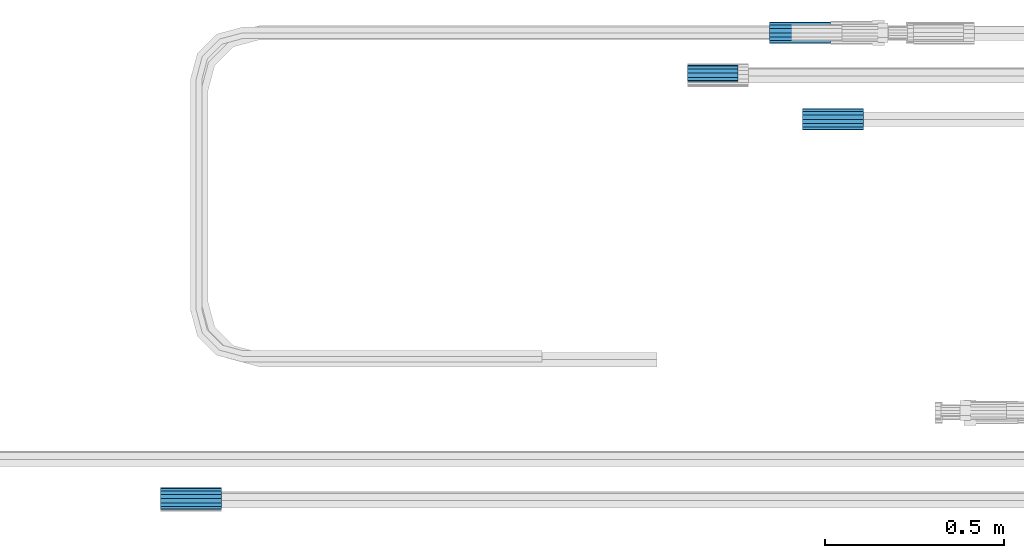
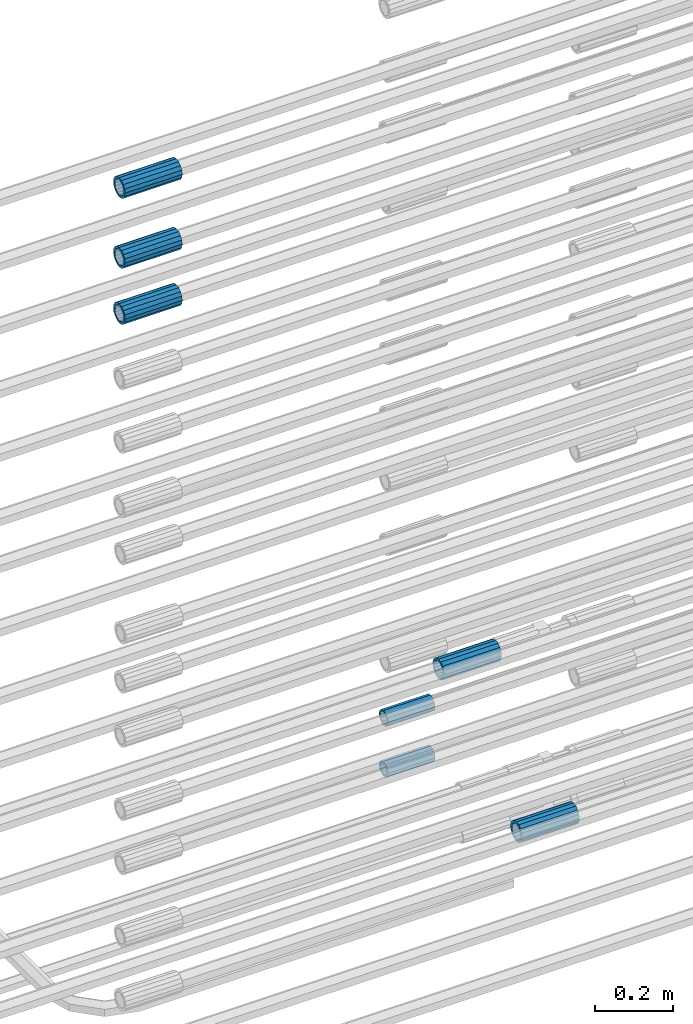
# One storey, part 6 of 119: 7 beams.
"""IFC2X3 building model written with IfcOpenShell, lengths in millimetres."""

from ifc_helpers import new_model, si_unit, frame, origin_with_axes, place, context, subcontext, project, spatial, faceted_brep, material, type_object, element, save


model = new_model("IFC2X3")

# Units and contexts
model_context = context("Model", 3, precision=1e-05, world=origin_with_axes())
body_context = subcontext(model_context, "Body", "Model", "MODEL_VIEW")
ifc_project = project(units=[si_unit("LENGTHUNIT", "METRE", prefix="MILLI"), si_unit("AREAUNIT", "SQUARE_METRE"), si_unit("VOLUMEUNIT", "CUBIC_METRE"), si_unit("MASSUNIT", "GRAM", prefix="KILO"), si_unit("TIMEUNIT", "SECOND"), si_unit("PLANEANGLEUNIT", "RADIAN"), si_unit("SOLIDANGLEUNIT", "STERADIAN"), si_unit("THERMODYNAMICTEMPERATUREUNIT", "DEGREE_CELSIUS"), si_unit("LUMINOUSINTENSITYUNIT", "LUMEN")], contexts=[model_context])

# Site, building, storey
site_placement = place(None, origin_with_axes())
site = spatial("IfcSite", under=ifc_project, at=site_placement, CompositionType="ELEMENT")
building_placement = place(site_placement, origin_with_axes())
building = spatial("IfcBuilding", under=site, at=building_placement, Name="Undefined", CompositionType="ELEMENT")
storey_placement = place(building_placement, origin_with_axes())
storey = spatial("IfcBuildingStorey", under=building, at=storey_placement, Name="Undefined", CompositionType="ELEMENT", Elevation=0.0)

# Beams
ifc_material = material(Name="STEEL/S275")
beam_type_1 = type_object("IfcBeamType", PredefinedType="NOTDEFINED")
beam_1_placement = place(storey_placement, frame((2031709.99007889, 6206160.98994599, 19018.4893064903), z_axis=(0.0, 0.0, 1.0), x_axis=(-0.99999999999998, 1.98000110685822e-07, 0.0)))
element("IfcBeam", 1, at=beam_1_placement, inside=storey, type_object=beam_type_1, material=ifc_material, Name="AG40N", context=body_context, shape_type="Brep", body=[
    faceted_brep([(1.62981450557709e-09, -23.4999999990687, 0.0), (7.45058059692383e-09, -21.7111690142192, 8.99306066057534), (170.000002125278, -21.711168999318, 8.99306066022245), (170.000002127141, -23.4999999844003, -3.66071617463604e-10), (4.65661287307739e-09, -16.6170093587134, 16.6170093578889), (170.000002122484, -16.6170093440451, 16.6170093575288), (1.86264514923096e-09, -8.99306066217832, 21.7111690140277), (170.000002118759, -8.99306064750999, 21.7111690136603), (2.3283064365387e-10, 9.31322574615479e-10, 23.5), (170.000002114102, 1.28056854009628e-08, 23.4999999996485), (-6.51925802230835e-09, 8.99306065868586, 21.7111690140241), (170.00000211224, 8.99306067335419, 21.7111690136639), (-7.45058059692383e-09, 16.6170093561523, 16.6170093578853), (170.000002109446, 16.6170093708206, 16.6170093575324), (-9.31322574615479e-09, 21.711169013055, 8.99306066057534), (170.000002108514, 21.7111690277234, 8.99306066022245), (-1.16415321826935e-09, 23.5000000009313, 0.0), (170.000002108514, 23.5000000144355, -3.66071617463604e-10), (-8.38190317153931e-09, 21.7111690151505, -8.99306066059444), (170.000002110377, 21.7111690300517, -8.9930606609546), (-5.58793544769287e-09, 16.6170093598776, -16.6170093579008), (170.000002113171, 16.6170093745459, -16.6170093582609), (-9.31322574615479e-10, 8.99306066334248, -21.7111690140396), (170.000002115965, 8.99306067801081, -21.7111690143961), (2.3283064365387e-10, 9.31322574615479e-10, -23.5), (170.00000211969, 1.7927959561348e-08, -23.5000000003843), (5.58793544769287e-09, -8.99306065752171, -21.7111690140396), (170.000002123415, -8.99306064285338, -21.7111690143961), (8.38190317153931e-09, -16.6170093549881, -16.6170093579008), (170.000002125278, -16.6170093403198, -16.6170093582646), (9.31322574615479e-09, -21.7111690121237, -8.99306066059444), (170.000002127141, -21.7111689972226, -8.9930606609546), (1.11758708953857e-08, -30.4999999990687, -9.54969436861575e-12), (1.30385160446167e-08, -28.1783257392235, -11.6718446871514), (170.000002129003, -28.1783257243223, -11.6718446875116), (170.000002129935, -30.4999999841675, -3.66071617463604e-10), (1.02445483207703e-08, -21.5667568228673, -21.5667568262129), (170.000002128072, -21.566756808199, -21.5667568265694), (7.45058059692383e-09, -11.6718446831219, -28.1783257416196), (170.000002125278, -11.6718446684536, -28.1783257419834), (3.72529029846191e-09, 3.95812094211578e-09, -30.5000000000277), (170.00000211969, 1.83936208486557e-08, -30.5000000003879), (-9.31322574615479e-10, 11.6718446905725, -28.1783257416232), (170.000002115965, 11.6718447052408, -28.1783257419797), (-6.51925802230835e-09, 21.5667568286881, -21.5667568262093), (170.000002110377, 21.5667568433564, -21.5667568265694), (-9.31322574615479e-09, 28.178325742716, -11.6718446871478), (170.000002108514, 28.1783257573843, -11.6718446875079), (-1.21071934700012e-08, 30.5, -5.91171556152403e-12), (170.000002106652, 30.5000000144355, -3.62433638656512e-10), (-1.21071934700012e-08, 28.1783257401548, 11.6718446871359), (170.00000210572, 28.1783257548232, 11.6718446867794), (-1.02445483207703e-08, 21.5667568240315, 21.5667568261974), (170.000002107583, 21.566756838467, 21.5667568258409), (-7.45058059692383e-09, 11.671844684286, 28.1783257416041), (170.000002110377, 11.6718446989544, 28.178325741244), (-2.79396772384644e-09, -2.56113708019257e-09, 30.5000000000159), (170.000002114102, 1.18743628263474e-08, 30.4999999996558), (1.86264514923096e-09, -11.6718446896411, 28.1783257416114), (170.000002118759, -11.67184467474, 28.178325741244), (7.45058059692383e-09, -21.5667568275239, 21.5667568261974), (170.000002123415, -21.5667568126228, 21.5667568258373), (1.02445483207703e-08, -28.1783257415518, 11.6718446871359), (170.000002127141, -28.1783257271163, 11.6718446867794)], [[[0, 1, 2, 3]], [[1, 4, 5, 2]], [[4, 6, 7, 5]], [[6, 8, 9, 7]], [[8, 10, 11, 9]], [[10, 12, 13, 11]], [[12, 14, 15, 13]], [[14, 16, 17, 15]], [[16, 18, 19, 17]], [[18, 20, 21, 19]], [[20, 22, 23, 21]], [[22, 24, 25, 23]], [[24, 26, 27, 25]], [[26, 28, 29, 27]], [[28, 30, 31, 29]], [[30, 0, 3, 31]], [[32, 33, 34, 35]], [[33, 36, 37, 34]], [[36, 38, 39, 37]], [[38, 40, 41, 39]], [[40, 42, 43, 41]], [[42, 44, 45, 43]], [[44, 46, 47, 45]], [[46, 48, 49, 47]], [[48, 50, 51, 49]], [[50, 52, 53, 51]], [[52, 54, 55, 53]], [[54, 56, 57, 55]], [[56, 58, 59, 57]], [[58, 60, 61, 59]], [[60, 62, 63, 61]], [[62, 32, 35, 63]], [[37, 39, 41, 43, 45, 47, 49, 51, 53, 55, 57, 59, 61, 63, 35, 34], [5, 7, 9, 11, 13, 15, 17, 19, 21, 23, 25, 27, 29, 31, 3, 2]], [[62, 60, 58, 56, 54, 52, 50, 48, 46, 44, 42, 40, 38, 36, 33, 32], [30, 28, 26, 24, 22, 20, 18, 16, 14, 12, 10, 8, 6, 4, 1, 0]]]),
])
beam_2_placement = place(storey_placement, frame((2031448.05849044, 6206402.19622464, 19414.9906870425), z_axis=(0.0, 0.0, 1.0), x_axis=(1.0, 0.0, 0.0)))
element("IfcBeam", 2, at=beam_2_placement, inside=storey, type_object=beam_type_1, material=ifc_material, Name="AG40N", context=body_context, shape_type="Brep", body=[
    faceted_brep([(1.62981450557709e-09, -23.4999999990687, 0.0), (7.45058059692383e-09, -21.7111690142192, 8.99306066057534), (170.000002125278, -21.711168999318, 8.99306066022245), (170.000002127141, -23.4999999844003, -3.66071617463604e-10), (4.65661287307739e-09, -16.6170093587134, 16.6170093578889), (170.000002122484, -16.6170093440451, 16.6170093575288), (1.86264514923096e-09, -8.99306066217832, 21.7111690140277), (170.000002118759, -8.99306064750999, 21.7111690136603), (2.3283064365387e-10, 9.31322574615479e-10, 23.5), (170.000002114102, 1.28056854009628e-08, 23.4999999996485), (-6.51925802230835e-09, 8.99306065868586, 21.7111690140241), (170.00000211224, 8.99306067335419, 21.7111690136639), (-7.45058059692383e-09, 16.6170093561523, 16.6170093578853), (170.000002109446, 16.6170093708206, 16.6170093575324), (-9.31322574615479e-09, 21.711169013055, 8.99306066057534), (170.000002108514, 21.7111690277234, 8.99306066022245), (-1.16415321826935e-09, 23.5000000009313, 0.0), (170.000002108514, 23.5000000144355, -3.66071617463604e-10), (-8.38190317153931e-09, 21.7111690151505, -8.99306066059444), (170.000002110377, 21.7111690300517, -8.9930606609546), (-5.58793544769287e-09, 16.6170093598776, -16.6170093579008), (170.000002113171, 16.6170093745459, -16.6170093582609), (-9.31322574615479e-10, 8.99306066334248, -21.7111690140396), (170.000002115965, 8.99306067801081, -21.7111690143961), (2.3283064365387e-10, 9.31322574615479e-10, -23.5), (170.00000211969, 1.7927959561348e-08, -23.5000000003843), (5.58793544769287e-09, -8.99306065752171, -21.7111690140396), (170.000002123415, -8.99306064285338, -21.7111690143961), (8.38190317153931e-09, -16.6170093549881, -16.6170093579008), (170.000002125278, -16.6170093403198, -16.6170093582646), (9.31322574615479e-09, -21.7111690121237, -8.99306066059444), (170.000002127141, -21.7111689972226, -8.9930606609546), (1.11758708953857e-08, -30.4999999990687, -9.54969436861575e-12), (1.30385160446167e-08, -28.1783257392235, -11.6718446871514), (170.000002129003, -28.1783257243223, -11.6718446875116), (170.000002129935, -30.4999999841675, -3.66071617463604e-10), (1.02445483207703e-08, -21.5667568228673, -21.5667568262129), (170.000002128072, -21.566756808199, -21.5667568265694), (7.45058059692383e-09, -11.6718446831219, -28.1783257416196), (170.000002125278, -11.6718446684536, -28.1783257419834), (3.72529029846191e-09, 3.95812094211578e-09, -30.5000000000277), (170.00000211969, 1.83936208486557e-08, -30.5000000003879), (-9.31322574615479e-10, 11.6718446905725, -28.1783257416232), (170.000002115965, 11.6718447052408, -28.1783257419797), (-6.51925802230835e-09, 21.5667568286881, -21.5667568262093), (170.000002110377, 21.5667568433564, -21.5667568265694), (-9.31322574615479e-09, 28.178325742716, -11.6718446871478), (170.000002108514, 28.1783257573843, -11.6718446875079), (-1.21071934700012e-08, 30.5, -5.91171556152403e-12), (170.000002106652, 30.5000000144355, -3.62433638656512e-10), (-1.21071934700012e-08, 28.1783257401548, 11.6718446871359), (170.00000210572, 28.1783257548232, 11.6718446867794), (-1.02445483207703e-08, 21.5667568240315, 21.5667568261974), (170.000002107583, 21.566756838467, 21.5667568258409), (-7.45058059692383e-09, 11.671844684286, 28.1783257416041), (170.000002110377, 11.6718446989544, 28.178325741244), (-2.79396772384644e-09, -2.56113708019257e-09, 30.5000000000159), (170.000002114102, 1.18743628263474e-08, 30.4999999996558), (1.86264514923096e-09, -11.6718446896411, 28.1783257416114), (170.000002118759, -11.67184467474, 28.178325741244), (7.45058059692383e-09, -21.5667568275239, 21.5667568261974), (170.000002123415, -21.5667568126228, 21.5667568258373), (1.02445483207703e-08, -28.1783257415518, 11.6718446871359), (170.000002127141, -28.1783257271163, 11.6718446867794)], [[[0, 1, 2, 3]], [[1, 4, 5, 2]], [[4, 6, 7, 5]], [[6, 8, 9, 7]], [[8, 10, 11, 9]], [[10, 12, 13, 11]], [[12, 14, 15, 13]], [[14, 16, 17, 15]], [[16, 18, 19, 17]], [[18, 20, 21, 19]], [[20, 22, 23, 21]], [[22, 24, 25, 23]], [[24, 26, 27, 25]], [[26, 28, 29, 27]], [[28, 30, 31, 29]], [[30, 0, 3, 31]], [[32, 33, 34, 35]], [[33, 36, 37, 34]], [[36, 38, 39, 37]], [[38, 40, 41, 39]], [[40, 42, 43, 41]], [[42, 44, 45, 43]], [[44, 46, 47, 45]], [[46, 48, 49, 47]], [[48, 50, 51, 49]], [[50, 52, 53, 51]], [[52, 54, 55, 53]], [[54, 56, 57, 55]], [[56, 58, 59, 57]], [[58, 60, 61, 59]], [[60, 62, 63, 61]], [[62, 32, 35, 63]], [[37, 39, 41, 43, 45, 47, 49, 51, 53, 55, 57, 59, 61, 63, 35, 34], [5, 7, 9, 11, 13, 15, 17, 19, 21, 23, 25, 27, 29, 31, 3, 2]], [[62, 60, 58, 56, 54, 52, 50, 48, 46, 44, 42, 40, 38, 36, 33, 32], [30, 28, 26, 24, 22, 20, 18, 16, 14, 12, 10, 8, 6, 4, 1, 0]]]),
])
beam_3_placement = place(storey_placement, frame((2029920.00007889, 6205102.98994599, 21913.4693052823), z_axis=(0.0, 0.0, 1.0), x_axis=(-0.99999999999998, 1.98000110685822e-07, 0.0)))
element("IfcBeam", 3, at=beam_3_placement, inside=storey, type_object=beam_type_1, material=ifc_material, Name="AG40N", context=body_context, shape_type="Brep", body=[
    faceted_brep([(1.62981450557709e-09, -23.4999999990687, 0.0), (7.45058059692383e-09, -21.7111690142192, 8.99306066057534), (170.000002125278, -21.711168999318, 8.99306066022245), (170.000002127141, -23.4999999844003, -3.66071617463604e-10), (4.65661287307739e-09, -16.6170093587134, 16.6170093578889), (170.000002122484, -16.6170093440451, 16.6170093575288), (1.86264514923096e-09, -8.99306066217832, 21.7111690140277), (170.000002118759, -8.99306064750999, 21.7111690136603), (2.3283064365387e-10, 9.31322574615479e-10, 23.5), (170.000002114102, 1.28056854009628e-08, 23.4999999996485), (-6.51925802230835e-09, 8.99306065868586, 21.7111690140241), (170.00000211224, 8.99306067335419, 21.7111690136639), (-7.45058059692383e-09, 16.6170093561523, 16.6170093578853), (170.000002109446, 16.6170093708206, 16.6170093575324), (-9.31322574615479e-09, 21.711169013055, 8.99306066057534), (170.000002108514, 21.7111690277234, 8.99306066022245), (-1.16415321826935e-09, 23.5000000009313, 0.0), (170.000002108514, 23.5000000144355, -3.66071617463604e-10), (-8.38190317153931e-09, 21.7111690151505, -8.99306066059444), (170.000002110377, 21.7111690300517, -8.9930606609546), (-5.58793544769287e-09, 16.6170093598776, -16.6170093579008), (170.000002113171, 16.6170093745459, -16.6170093582609), (-9.31322574615479e-10, 8.99306066334248, -21.7111690140396), (170.000002115965, 8.99306067801081, -21.7111690143961), (2.3283064365387e-10, 9.31322574615479e-10, -23.5), (170.00000211969, 1.7927959561348e-08, -23.5000000003843), (5.58793544769287e-09, -8.99306065752171, -21.7111690140396), (170.000002123415, -8.99306064285338, -21.7111690143961), (8.38190317153931e-09, -16.6170093549881, -16.6170093579008), (170.000002125278, -16.6170093403198, -16.6170093582646), (9.31322574615479e-09, -21.7111690121237, -8.99306066059444), (170.000002127141, -21.7111689972226, -8.9930606609546), (1.11758708953857e-08, -30.4999999990687, -9.54969436861575e-12), (1.30385160446167e-08, -28.1783257392235, -11.6718446871514), (170.000002129003, -28.1783257243223, -11.6718446875116), (170.000002129935, -30.4999999841675, -3.66071617463604e-10), (1.02445483207703e-08, -21.5667568228673, -21.5667568262129), (170.000002128072, -21.566756808199, -21.5667568265694), (7.45058059692383e-09, -11.6718446831219, -28.1783257416196), (170.000002125278, -11.6718446684536, -28.1783257419834), (3.72529029846191e-09, 3.95812094211578e-09, -30.5000000000277), (170.00000211969, 1.83936208486557e-08, -30.5000000003879), (-9.31322574615479e-10, 11.6718446905725, -28.1783257416232), (170.000002115965, 11.6718447052408, -28.1783257419797), (-6.51925802230835e-09, 21.5667568286881, -21.5667568262093), (170.000002110377, 21.5667568433564, -21.5667568265694), (-9.31322574615479e-09, 28.178325742716, -11.6718446871478), (170.000002108514, 28.1783257573843, -11.6718446875079), (-1.21071934700012e-08, 30.5, -5.91171556152403e-12), (170.000002106652, 30.5000000144355, -3.62433638656512e-10), (-1.21071934700012e-08, 28.1783257401548, 11.6718446871359), (170.00000210572, 28.1783257548232, 11.6718446867794), (-1.02445483207703e-08, 21.5667568240315, 21.5667568261974), (170.000002107583, 21.566756838467, 21.5667568258409), (-7.45058059692383e-09, 11.671844684286, 28.1783257416041), (170.000002110377, 11.6718446989544, 28.178325741244), (-2.79396772384644e-09, -2.56113708019257e-09, 30.5000000000159), (170.000002114102, 1.18743628263474e-08, 30.4999999996558), (1.86264514923096e-09, -11.6718446896411, 28.1783257416114), (170.000002118759, -11.67184467474, 28.178325741244), (7.45058059692383e-09, -21.5667568275239, 21.5667568261974), (170.000002123415, -21.5667568126228, 21.5667568258373), (1.02445483207703e-08, -28.1783257415518, 11.6718446871359), (170.000002127141, -28.1783257271163, 11.6718446867794)], [[[0, 1, 2, 3]], [[1, 4, 5, 2]], [[4, 6, 7, 5]], [[6, 8, 9, 7]], [[8, 10, 11, 9]], [[10, 12, 13, 11]], [[12, 14, 15, 13]], [[14, 16, 17, 15]], [[16, 18, 19, 17]], [[18, 20, 21, 19]], [[20, 22, 23, 21]], [[22, 24, 25, 23]], [[24, 26, 27, 25]], [[26, 28, 29, 27]], [[28, 30, 31, 29]], [[30, 0, 3, 31]], [[32, 33, 34, 35]], [[33, 36, 37, 34]], [[36, 38, 39, 37]], [[38, 40, 41, 39]], [[40, 42, 43, 41]], [[42, 44, 45, 43]], [[44, 46, 47, 45]], [[46, 48, 49, 47]], [[48, 50, 51, 49]], [[50, 52, 53, 51]], [[52, 54, 55, 53]], [[54, 56, 57, 55]], [[56, 58, 59, 57]], [[58, 60, 61, 59]], [[60, 62, 63, 61]], [[62, 32, 35, 63]], [[37, 39, 41, 43, 45, 47, 49, 51, 53, 55, 57, 59, 61, 63, 35, 34], [5, 7, 9, 11, 13, 15, 17, 19, 21, 23, 25, 27, 29, 31, 3, 2]], [[62, 60, 58, 56, 54, 52, 50, 48, 46, 44, 42, 40, 38, 36, 33, 32], [30, 28, 26, 24, 22, 20, 18, 16, 14, 12, 10, 8, 6, 4, 1, 0]]]),
])
beam_4_placement = place(storey_placement, frame((2029920.00007889, 6205102.98994599, 22089.4693052823), z_axis=(0.0, 0.0, 1.0), x_axis=(-0.99999999999998, 1.98000110685822e-07, 0.0)))
element("IfcBeam", 4, at=beam_4_placement, inside=storey, type_object=beam_type_1, material=ifc_material, Name="AG40N", context=body_context, shape_type="Brep", body=[
    faceted_brep([(1.62981450557709e-09, -23.4999999990687, 0.0), (7.45058059692383e-09, -21.7111690142192, 8.99306066057534), (170.000002125278, -21.711168999318, 8.99306066022245), (170.000002127141, -23.4999999844003, -3.66071617463604e-10), (4.65661287307739e-09, -16.6170093587134, 16.6170093578889), (170.000002122484, -16.6170093440451, 16.6170093575288), (1.86264514923096e-09, -8.99306066217832, 21.7111690140277), (170.000002118759, -8.99306064750999, 21.7111690136603), (2.3283064365387e-10, 9.31322574615479e-10, 23.5), (170.000002114102, 1.28056854009628e-08, 23.4999999996485), (-6.51925802230835e-09, 8.99306065868586, 21.7111690140241), (170.00000211224, 8.99306067335419, 21.7111690136639), (-7.45058059692383e-09, 16.6170093561523, 16.6170093578853), (170.000002109446, 16.6170093708206, 16.6170093575324), (-9.31322574615479e-09, 21.711169013055, 8.99306066057534), (170.000002108514, 21.7111690277234, 8.99306066022245), (-1.16415321826935e-09, 23.5000000009313, 0.0), (170.000002108514, 23.5000000144355, -3.66071617463604e-10), (-8.38190317153931e-09, 21.7111690151505, -8.99306066059444), (170.000002110377, 21.7111690300517, -8.9930606609546), (-5.58793544769287e-09, 16.6170093598776, -16.6170093579008), (170.000002113171, 16.6170093745459, -16.6170093582609), (-9.31322574615479e-10, 8.99306066334248, -21.7111690140396), (170.000002115965, 8.99306067801081, -21.7111690143961), (2.3283064365387e-10, 9.31322574615479e-10, -23.5), (170.00000211969, 1.7927959561348e-08, -23.5000000003843), (5.58793544769287e-09, -8.99306065752171, -21.7111690140396), (170.000002123415, -8.99306064285338, -21.7111690143961), (8.38190317153931e-09, -16.6170093549881, -16.6170093579008), (170.000002125278, -16.6170093403198, -16.6170093582646), (9.31322574615479e-09, -21.7111690121237, -8.99306066059444), (170.000002127141, -21.7111689972226, -8.9930606609546), (1.11758708953857e-08, -30.4999999990687, -9.54969436861575e-12), (1.30385160446167e-08, -28.1783257392235, -11.6718446871514), (170.000002129003, -28.1783257243223, -11.6718446875116), (170.000002129935, -30.4999999841675, -3.66071617463604e-10), (1.02445483207703e-08, -21.5667568228673, -21.5667568262129), (170.000002128072, -21.566756808199, -21.5667568265694), (7.45058059692383e-09, -11.6718446831219, -28.1783257416196), (170.000002125278, -11.6718446684536, -28.1783257419834), (3.72529029846191e-09, 3.95812094211578e-09, -30.5000000000277), (170.00000211969, 1.83936208486557e-08, -30.5000000003879), (-9.31322574615479e-10, 11.6718446905725, -28.1783257416232), (170.000002115965, 11.6718447052408, -28.1783257419797), (-6.51925802230835e-09, 21.5667568286881, -21.5667568262093), (170.000002110377, 21.5667568433564, -21.5667568265694), (-9.31322574615479e-09, 28.178325742716, -11.6718446871478), (170.000002108514, 28.1783257573843, -11.6718446875079), (-1.21071934700012e-08, 30.5, -5.91171556152403e-12), (170.000002106652, 30.5000000144355, -3.62433638656512e-10), (-1.21071934700012e-08, 28.1783257401548, 11.6718446871359), (170.00000210572, 28.1783257548232, 11.6718446867794), (-1.02445483207703e-08, 21.5667568240315, 21.5667568261974), (170.000002107583, 21.566756838467, 21.5667568258409), (-7.45058059692383e-09, 11.671844684286, 28.1783257416041), (170.000002110377, 11.6718446989544, 28.178325741244), (-2.79396772384644e-09, -2.56113708019257e-09, 30.5000000000159), (170.000002114102, 1.18743628263474e-08, 30.4999999996558), (1.86264514923096e-09, -11.6718446896411, 28.1783257416114), (170.000002118759, -11.67184467474, 28.178325741244), (7.45058059692383e-09, -21.5667568275239, 21.5667568261974), (170.000002123415, -21.5667568126228, 21.5667568258373), (1.02445483207703e-08, -28.1783257415518, 11.6718446871359), (170.000002127141, -28.1783257271163, 11.6718446867794)], [[[0, 1, 2, 3]], [[1, 4, 5, 2]], [[4, 6, 7, 5]], [[6, 8, 9, 7]], [[8, 10, 11, 9]], [[10, 12, 13, 11]], [[12, 14, 15, 13]], [[14, 16, 17, 15]], [[16, 18, 19, 17]], [[18, 20, 21, 19]], [[20, 22, 23, 21]], [[22, 24, 25, 23]], [[24, 26, 27, 25]], [[26, 28, 29, 27]], [[28, 30, 31, 29]], [[30, 0, 3, 31]], [[32, 33, 34, 35]], [[33, 36, 37, 34]], [[36, 38, 39, 37]], [[38, 40, 41, 39]], [[40, 42, 43, 41]], [[42, 44, 45, 43]], [[44, 46, 47, 45]], [[46, 48, 49, 47]], [[48, 50, 51, 49]], [[50, 52, 53, 51]], [[52, 54, 55, 53]], [[54, 56, 57, 55]], [[56, 58, 59, 57]], [[58, 60, 61, 59]], [[60, 62, 63, 61]], [[62, 32, 35, 63]], [[37, 39, 41, 43, 45, 47, 49, 51, 53, 55, 57, 59, 61, 63, 35, 34], [5, 7, 9, 11, 13, 15, 17, 19, 21, 23, 25, 27, 29, 31, 3, 2]], [[62, 60, 58, 56, 54, 52, 50, 48, 46, 44, 42, 40, 38, 36, 33, 32], [30, 28, 26, 24, 22, 20, 18, 16, 14, 12, 10, 8, 6, 4, 1, 0]]]),
])
beam_5_placement = place(storey_placement, frame((2029920.00007889, 6205102.98994599, 22308.9893052724), z_axis=(0.0, 0.0, 1.0), x_axis=(-0.99999999999998, 1.98000110685822e-07, 0.0)))
element("IfcBeam", 5, at=beam_5_placement, inside=storey, type_object=beam_type_1, material=ifc_material, Name="AG40N", context=body_context, shape_type="Brep", body=[
    faceted_brep([(1.62981450557709e-09, -23.4999999990687, 0.0), (7.45058059692383e-09, -21.7111690142192, 8.99306066057534), (170.000002125278, -21.711168999318, 8.99306066022245), (170.000002127141, -23.4999999844003, -3.66071617463604e-10), (4.65661287307739e-09, -16.6170093587134, 16.6170093578889), (170.000002122484, -16.6170093440451, 16.6170093575288), (1.86264514923096e-09, -8.99306066217832, 21.7111690140277), (170.000002118759, -8.99306064750999, 21.7111690136603), (2.3283064365387e-10, 9.31322574615479e-10, 23.5), (170.000002114102, 1.28056854009628e-08, 23.4999999996485), (-6.51925802230835e-09, 8.99306065868586, 21.7111690140241), (170.00000211224, 8.99306067335419, 21.7111690136639), (-7.45058059692383e-09, 16.6170093561523, 16.6170093578853), (170.000002109446, 16.6170093708206, 16.6170093575324), (-9.31322574615479e-09, 21.711169013055, 8.99306066057534), (170.000002108514, 21.7111690277234, 8.99306066022245), (-1.16415321826935e-09, 23.5000000009313, 0.0), (170.000002108514, 23.5000000144355, -3.66071617463604e-10), (-8.38190317153931e-09, 21.7111690151505, -8.99306066059444), (170.000002110377, 21.7111690300517, -8.9930606609546), (-5.58793544769287e-09, 16.6170093598776, -16.6170093579008), (170.000002113171, 16.6170093745459, -16.6170093582609), (-9.31322574615479e-10, 8.99306066334248, -21.7111690140396), (170.000002115965, 8.99306067801081, -21.7111690143961), (2.3283064365387e-10, 9.31322574615479e-10, -23.5), (170.00000211969, 1.7927959561348e-08, -23.5000000003843), (5.58793544769287e-09, -8.99306065752171, -21.7111690140396), (170.000002123415, -8.99306064285338, -21.7111690143961), (8.38190317153931e-09, -16.6170093549881, -16.6170093579008), (170.000002125278, -16.6170093403198, -16.6170093582646), (9.31322574615479e-09, -21.7111690121237, -8.99306066059444), (170.000002127141, -21.7111689972226, -8.9930606609546), (1.11758708953857e-08, -30.4999999990687, -9.54969436861575e-12), (1.30385160446167e-08, -28.1783257392235, -11.6718446871514), (170.000002129003, -28.1783257243223, -11.6718446875116), (170.000002129935, -30.4999999841675, -3.66071617463604e-10), (1.02445483207703e-08, -21.5667568228673, -21.5667568262129), (170.000002128072, -21.566756808199, -21.5667568265694), (7.45058059692383e-09, -11.6718446831219, -28.1783257416196), (170.000002125278, -11.6718446684536, -28.1783257419834), (3.72529029846191e-09, 3.95812094211578e-09, -30.5000000000277), (170.00000211969, 1.83936208486557e-08, -30.5000000003879), (-9.31322574615479e-10, 11.6718446905725, -28.1783257416232), (170.000002115965, 11.6718447052408, -28.1783257419797), (-6.51925802230835e-09, 21.5667568286881, -21.5667568262093), (170.000002110377, 21.5667568433564, -21.5667568265694), (-9.31322574615479e-09, 28.178325742716, -11.6718446871478), (170.000002108514, 28.1783257573843, -11.6718446875079), (-1.21071934700012e-08, 30.5, -5.91171556152403e-12), (170.000002106652, 30.5000000144355, -3.62433638656512e-10), (-1.21071934700012e-08, 28.1783257401548, 11.6718446871359), (170.00000210572, 28.1783257548232, 11.6718446867794), (-1.02445483207703e-08, 21.5667568240315, 21.5667568261974), (170.000002107583, 21.566756838467, 21.5667568258409), (-7.45058059692383e-09, 11.671844684286, 28.1783257416041), (170.000002110377, 11.6718446989544, 28.178325741244), (-2.79396772384644e-09, -2.56113708019257e-09, 30.5000000000159), (170.000002114102, 1.18743628263474e-08, 30.4999999996558), (1.86264514923096e-09, -11.6718446896411, 28.1783257416114), (170.000002118759, -11.67184467474, 28.178325741244), (7.45058059692383e-09, -21.5667568275239, 21.5667568261974), (170.000002123415, -21.5667568126228, 21.5667568258373), (1.02445483207703e-08, -28.1783257415518, 11.6718446871359), (170.000002127141, -28.1783257271163, 11.6718446867794)], [[[0, 1, 2, 3]], [[1, 4, 5, 2]], [[4, 6, 7, 5]], [[6, 8, 9, 7]], [[8, 10, 11, 9]], [[10, 12, 13, 11]], [[12, 14, 15, 13]], [[14, 16, 17, 15]], [[16, 18, 19, 17]], [[18, 20, 21, 19]], [[20, 22, 23, 21]], [[22, 24, 25, 23]], [[24, 26, 27, 25]], [[26, 28, 29, 27]], [[28, 30, 31, 29]], [[30, 0, 3, 31]], [[32, 33, 34, 35]], [[33, 36, 37, 34]], [[36, 38, 39, 37]], [[38, 40, 41, 39]], [[40, 42, 43, 41]], [[42, 44, 45, 43]], [[44, 46, 47, 45]], [[46, 48, 49, 47]], [[48, 50, 51, 49]], [[50, 52, 53, 51]], [[52, 54, 55, 53]], [[54, 56, 57, 55]], [[56, 58, 59, 57]], [[58, 60, 61, 59]], [[60, 62, 63, 61]], [[62, 32, 35, 63]], [[37, 39, 41, 43, 45, 47, 49, 51, 53, 55, 57, 59, 61, 63, 35, 34], [5, 7, 9, 11, 13, 15, 17, 19, 21, 23, 25, 27, 29, 31, 3, 2]], [[62, 60, 58, 56, 54, 52, 50, 48, 46, 44, 42, 40, 38, 36, 33, 32], [30, 28, 26, 24, 22, 20, 18, 16, 14, 12, 10, 8, 6, 4, 1, 0]]]),
])
beam_type_2 = type_object("IfcBeamType", PredefinedType="NOTDEFINED")
beam_6_placement = place(storey_placement, frame((2031220.00007889, 6206289.47994599, 19249.4893046785), z_axis=(0.0, 0.0, 1.0), x_axis=(1.0, 0.0, 0.0)))
element("IfcBeam", 6, at=beam_6_placement, inside=storey, type_object=beam_type_2, material=ifc_material, Name="AG32N", context=body_context, shape_type="Brep", body=[
    faceted_brep([(1.39698386192322e-09, -18.4999999990687, 0.0), (1.16415321826935e-09, -16.0214699693024, 9.25), (140.000000001164, -16.0214699935168, 9.25), (140.000000001397, -18.5000000232831, 0.0), (6.98491930961609e-10, -9.24999999906868, 16.0214699700118), (140.000000000698, -9.25000002328306, 16.0214699700118), (2.3283064365387e-10, 9.31322574615479e-10, 18.5), (140.000000000233, -2.3283064365387e-08, 18.5), (-2.3283064365387e-10, 9.25000000093132, 16.0214699700118), (139.999999999767, 9.24999997671694, 16.0214699700118), (-6.98491930961609e-10, 16.0214699711651, 9.25), (139.999999999302, 16.0214699469507, 9.25), (-9.31322574615479e-10, 18.5000000009313, 0.0), (139.999999999069, 18.4999999767169, 0.0), (-6.98491930961609e-10, 16.0214699711651, -9.25), (139.999999999302, 16.0214699469507, -9.25), (-2.3283064365387e-10, 9.25000000093132, -16.0214699700118), (139.999999999767, 9.24999997671694, -16.0214699700118), (2.3283064365387e-10, 9.31322574615479e-10, -18.5), (140.000000000233, -2.3283064365387e-08, -18.5), (6.98491930961609e-10, -9.24999999906868, -16.0214699700118), (140.000000000698, -9.25000002328306, -16.0214699700118), (1.16415321826935e-09, -16.0214699693024, -9.25), (140.000000001164, -16.0214699935168, -9.25), (1.62981450557709e-09, -23.4999999990687, 0.0), (1.39698386192322e-09, -20.3515969878063, -11.75), (140.000000001397, -20.3515970120206, -11.75), (140.00000000163, -23.5000000232831, 0.0), (9.31322574615479e-10, -11.7499999990687, -20.351596988934), (140.000000000931, -11.7500000232831, -20.351596988934), (2.3283064365387e-10, 9.31322574615479e-10, -23.5), (140.000000000233, -2.3283064365387e-08, -23.5), (-4.65661287307739e-10, 11.7500000009313, -20.351596988934), (139.999999999534, 11.7499999767169, -20.351596988934), (-9.31322574615479e-10, 20.3515969896689, -11.75), (139.999999999069, 20.3515969654545, -11.75), (-1.16415321826935e-09, 23.5000000009313, 0.0), (139.999999998836, 23.4999999767169, 0.0), (-9.31322574615479e-10, 20.3515969896689, 11.75), (139.999999999069, 20.3515969654545, 11.75), (-4.65661287307739e-10, 11.7500000009313, 20.351596988934), (139.999999999534, 11.7499999767169, 20.351596988934), (2.3283064365387e-10, 9.31322574615479e-10, 23.5), (140.000000000233, -2.3283064365387e-08, 23.5), (9.31322574615479e-10, -11.7499999990687, 20.351596988934), (140.000000000931, -11.7500000232831, 20.351596988934), (1.39698386192322e-09, -20.3515969878063, 11.75), (140.000000001397, -20.3515970120206, 11.75)], [[[0, 1, 2, 3]], [[1, 4, 5, 2]], [[4, 6, 7, 5]], [[6, 8, 9, 7]], [[8, 10, 11, 9]], [[10, 12, 13, 11]], [[12, 14, 15, 13]], [[14, 16, 17, 15]], [[16, 18, 19, 17]], [[18, 20, 21, 19]], [[20, 22, 23, 21]], [[22, 0, 3, 23]], [[24, 25, 26, 27]], [[25, 28, 29, 26]], [[28, 30, 31, 29]], [[30, 32, 33, 31]], [[32, 34, 35, 33]], [[34, 36, 37, 35]], [[36, 38, 39, 37]], [[38, 40, 41, 39]], [[40, 42, 43, 41]], [[42, 44, 45, 43]], [[44, 46, 47, 45]], [[46, 24, 27, 47]], [[29, 31, 33, 35, 37, 39, 41, 43, 45, 47, 27, 26], [5, 7, 9, 11, 13, 15, 17, 19, 21, 23, 3, 2]], [[46, 44, 42, 40, 38, 36, 34, 32, 30, 28, 25, 24], [22, 20, 18, 16, 14, 12, 10, 8, 6, 4, 1, 0]]]),
])
beam_7_placement = place(storey_placement, frame((2031220.00007889, 6206289.47994599, 19409.4893046785), z_axis=(0.0, 0.0, 1.0), x_axis=(1.0, 0.0, 0.0)))
element("IfcBeam", 7, at=beam_7_placement, inside=storey, type_object=beam_type_2, material=ifc_material, Name="AG32N", context=body_context, shape_type="Brep", body=[
    faceted_brep([(1.39698386192322e-09, -18.4999999990687, 0.0), (1.16415321826935e-09, -16.0214699693024, 9.25), (140.000000001164, -16.0214699935168, 9.25), (140.000000001397, -18.5000000232831, 0.0), (6.98491930961609e-10, -9.24999999906868, 16.0214699700118), (140.000000000698, -9.25000002328306, 16.0214699700118), (2.3283064365387e-10, 9.31322574615479e-10, 18.5), (140.000000000233, -2.3283064365387e-08, 18.5), (-2.3283064365387e-10, 9.25000000093132, 16.0214699700118), (139.999999999767, 9.24999997671694, 16.0214699700118), (-6.98491930961609e-10, 16.0214699711651, 9.25), (139.999999999302, 16.0214699469507, 9.25), (-9.31322574615479e-10, 18.5000000009313, 0.0), (139.999999999069, 18.4999999767169, 0.0), (-6.98491930961609e-10, 16.0214699711651, -9.25), (139.999999999302, 16.0214699469507, -9.25), (-2.3283064365387e-10, 9.25000000093132, -16.0214699700118), (139.999999999767, 9.24999997671694, -16.0214699700118), (2.3283064365387e-10, 9.31322574615479e-10, -18.5), (140.000000000233, -2.3283064365387e-08, -18.5), (6.98491930961609e-10, -9.24999999906868, -16.0214699700118), (140.000000000698, -9.25000002328306, -16.0214699700118), (1.16415321826935e-09, -16.0214699693024, -9.25), (140.000000001164, -16.0214699935168, -9.25), (1.62981450557709e-09, -23.4999999990687, 0.0), (1.39698386192322e-09, -20.3515969878063, -11.75), (140.000000001397, -20.3515970120206, -11.75), (140.00000000163, -23.5000000232831, 0.0), (9.31322574615479e-10, -11.7499999990687, -20.351596988934), (140.000000000931, -11.7500000232831, -20.351596988934), (2.3283064365387e-10, 9.31322574615479e-10, -23.5), (140.000000000233, -2.3283064365387e-08, -23.5), (-4.65661287307739e-10, 11.7500000009313, -20.351596988934), (139.999999999534, 11.7499999767169, -20.351596988934), (-9.31322574615479e-10, 20.3515969896689, -11.75), (139.999999999069, 20.3515969654545, -11.75), (-1.16415321826935e-09, 23.5000000009313, 0.0), (139.999999998836, 23.4999999767169, 0.0), (-9.31322574615479e-10, 20.3515969896689, 11.75), (139.999999999069, 20.3515969654545, 11.75), (-4.65661287307739e-10, 11.7500000009313, 20.351596988934), (139.999999999534, 11.7499999767169, 20.351596988934), (2.3283064365387e-10, 9.31322574615479e-10, 23.5), (140.000000000233, -2.3283064365387e-08, 23.5), (9.31322574615479e-10, -11.7499999990687, 20.351596988934), (140.000000000931, -11.7500000232831, 20.351596988934), (1.39698386192322e-09, -20.3515969878063, 11.75), (140.000000001397, -20.3515970120206, 11.75)], [[[0, 1, 2, 3]], [[1, 4, 5, 2]], [[4, 6, 7, 5]], [[6, 8, 9, 7]], [[8, 10, 11, 9]], [[10, 12, 13, 11]], [[12, 14, 15, 13]], [[14, 16, 17, 15]], [[16, 18, 19, 17]], [[18, 20, 21, 19]], [[20, 22, 23, 21]], [[22, 0, 3, 23]], [[24, 25, 26, 27]], [[25, 28, 29, 26]], [[28, 30, 31, 29]], [[30, 32, 33, 31]], [[32, 34, 35, 33]], [[34, 36, 37, 35]], [[36, 38, 39, 37]], [[38, 40, 41, 39]], [[40, 42, 43, 41]], [[42, 44, 45, 43]], [[44, 46, 47, 45]], [[46, 24, 27, 47]], [[29, 31, 33, 35, 37, 39, 41, 43, 45, 47, 27, 26], [5, 7, 9, 11, 13, 15, 17, 19, 21, 23, 3, 2]], [[46, 44, 42, 40, 38, 36, 34, 32, 30, 28, 25, 24], [22, 20, 18, 16, 14, 12, 10, 8, 6, 4, 1, 0]]]),
])

save(model, "model.ifc")
